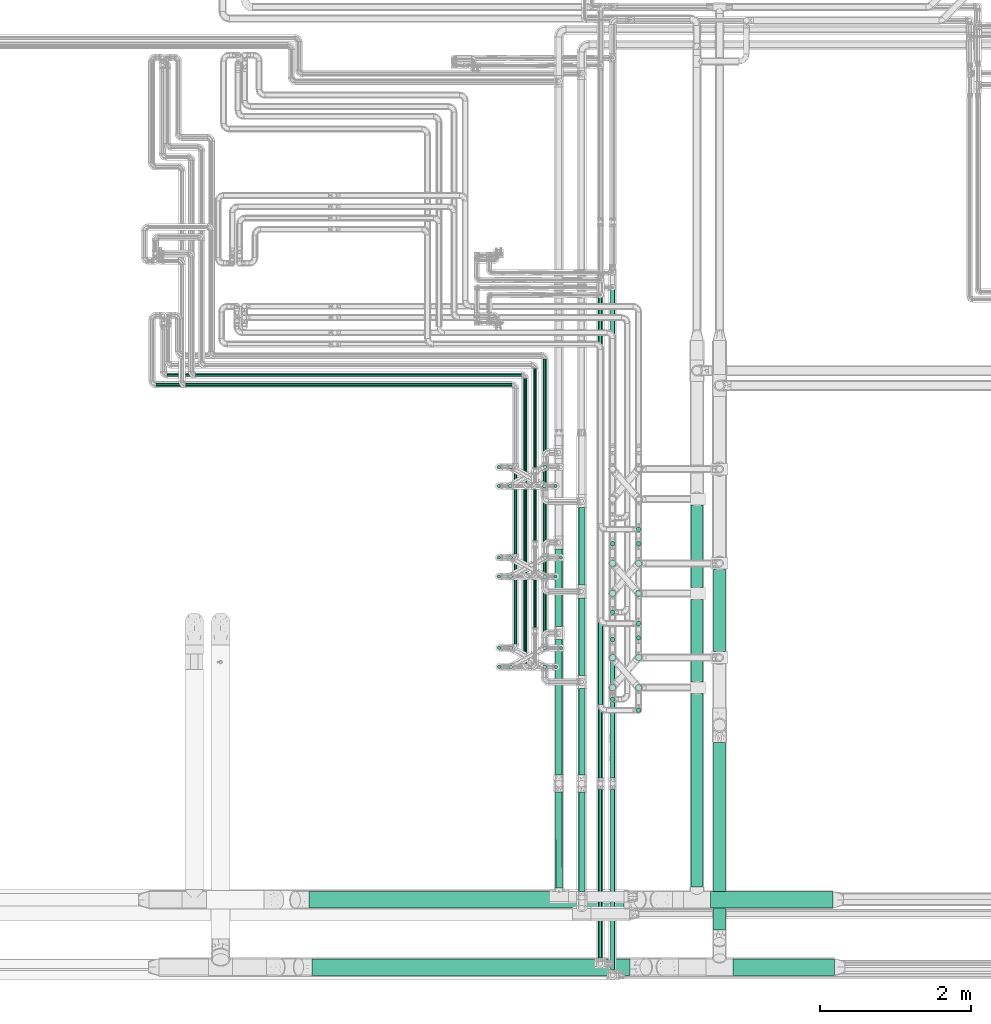
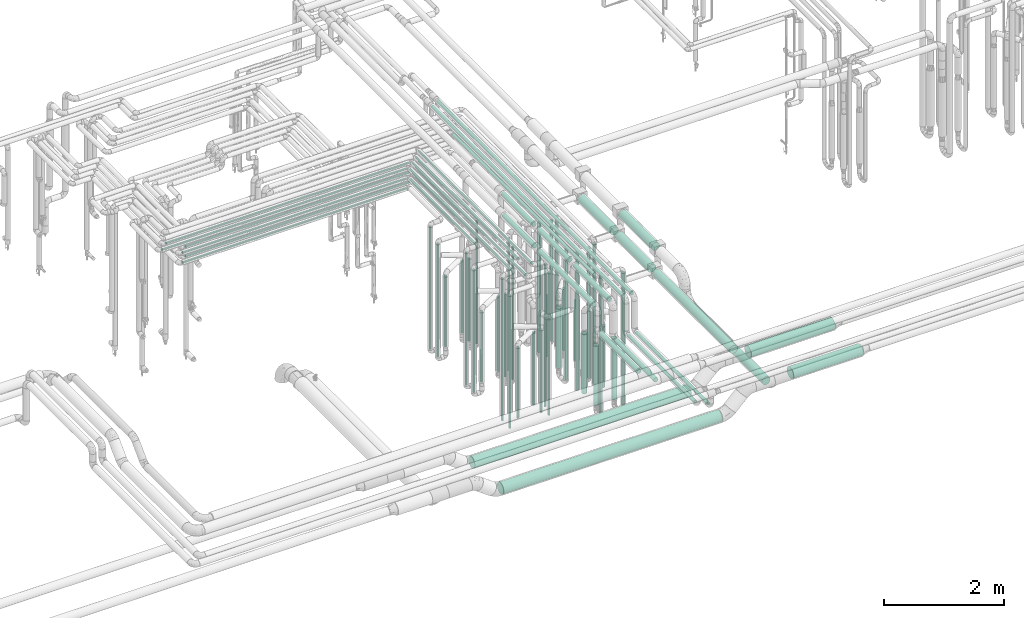
# One storey, part 530 of 827: 78 flow segments.
"""IFC2X3 building model written with IfcOpenShell, lengths in millimetres."""

from ifc_helpers import new_model, entity, si_unit, converted_unit, derived_unit, direction, frame, origin, origin_2d_with_axis, place, context, subcontext, project, spatial, polyline, circle, outline, extrude, type_object, element, save


model = new_model("IFC2X3")

# Units and contexts
model_context = context("Model", 3, precision=0.01, world=origin(), true_north=direction((6.12303176911189e-17, 1.0)))
body_context = subcontext(model_context, "Body", "Model", "MODEL_VIEW")
ifc_project = project(units=[si_unit("LENGTHUNIT", "METRE", prefix="MILLI"), si_unit("AREAUNIT", "SQUARE_METRE"), si_unit("VOLUMEUNIT", "CUBIC_METRE"), converted_unit("PLANEANGLEUNIT", "DEGREE", entity("IfcRatioMeasure", 0.0174532925199433), si_unit("PLANEANGLEUNIT", "RADIAN"), dimensions=[0, 0, 0, 0, 0, 0, 0]), si_unit("MASSUNIT", "GRAM", prefix="KILO"), derived_unit("MASSDENSITYUNIT", [(si_unit("MASSUNIT", "GRAM", prefix="KILO"), 1), (si_unit("LENGTHUNIT", "METRE"), -3)]), derived_unit("MOMENTOFINERTIAUNIT", [(si_unit("LENGTHUNIT", "METRE"), 4)]), si_unit("TIMEUNIT", "SECOND"), si_unit("FREQUENCYUNIT", "HERTZ"), si_unit("THERMODYNAMICTEMPERATUREUNIT", "DEGREE_CELSIUS"), derived_unit("THERMALTRANSMITTANCEUNIT", [(si_unit("MASSUNIT", "GRAM", prefix="KILO"), 1), (si_unit("THERMODYNAMICTEMPERATUREUNIT", "KELVIN"), -1), (si_unit("TIMEUNIT", "SECOND"), -3)]), derived_unit("VOLUMETRICFLOWRATEUNIT", [(si_unit("LENGTHUNIT", "METRE"), 3), (si_unit("TIMEUNIT", "SECOND"), -1)]), derived_unit("MASSFLOWRATEUNIT", [(si_unit("MASSUNIT", "GRAM", prefix="KILO"), 1), (si_unit("TIMEUNIT", "SECOND"), -1)]), derived_unit("ROTATIONALFREQUENCYUNIT", [(si_unit("TIMEUNIT", "SECOND"), -1)]), si_unit("ELECTRICCURRENTUNIT", "AMPERE"), si_unit("ELECTRICVOLTAGEUNIT", "VOLT"), si_unit("POWERUNIT", "WATT"), si_unit("FORCEUNIT", "NEWTON", prefix="KILO"), si_unit("ILLUMINANCEUNIT", "LUX"), si_unit("LUMINOUSFLUXUNIT", "LUMEN"), si_unit("LUMINOUSINTENSITYUNIT", "CANDELA"), derived_unit("USERDEFINED", [(si_unit("MASSUNIT", "GRAM", prefix="KILO"), -1), (si_unit("LENGTHUNIT", "METRE"), -2), (si_unit("TIMEUNIT", "SECOND"), 3), (si_unit("LUMINOUSFLUXUNIT", "LUMEN"), 1)]), derived_unit("LINEARVELOCITYUNIT", [(si_unit("LENGTHUNIT", "METRE"), 1), (si_unit("TIMEUNIT", "SECOND"), -1)]), si_unit("PRESSUREUNIT", "PASCAL"), derived_unit("USERDEFINED", [(si_unit("LENGTHUNIT", "METRE"), -2), (si_unit("MASSUNIT", "GRAM", prefix="KILO"), 1), (si_unit("TIMEUNIT", "SECOND"), -2)]), derived_unit("LINEARFORCEUNIT", [(si_unit("MASSUNIT", "GRAM", prefix="KILO"), 1), (si_unit("LENGTHUNIT", "METRE"), 1), (si_unit("TIMEUNIT", "SECOND"), -2), (si_unit("LENGTHUNIT", "METRE"), -1)]), derived_unit("PLANARFORCEUNIT", [(si_unit("MASSUNIT", "GRAM", prefix="KILO"), 1), (si_unit("LENGTHUNIT", "METRE"), 1), (si_unit("TIMEUNIT", "SECOND"), -2), (si_unit("LENGTHUNIT", "METRE"), -2)])], contexts=[model_context])

# Site, building, storey
site_placement = place(None, origin())
site = spatial("IfcSite", under=ifc_project, at=site_placement, CompositionType="ELEMENT")
building_placement = place(site_placement, origin())
building = spatial("IfcBuilding", under=site, at=building_placement, CompositionType="ELEMENT")
storey_placement = place(building_placement, frame((0.0, 0.0, 28200.0)))
storey = spatial("IfcBuildingStorey", under=building, at=storey_placement, Name="08", CompositionType="ELEMENT", Elevation=28200.0)

# Flow segments
pipe_segment_type_1 = type_object("IfcPipeSegmentType", PredefinedType="NOTDEFINED")
flow_segment_1_placement = place(storey_placement, frame((37926.3, 7155.11, 2788.77)))
element("IfcFlowSegment", 1, at=flow_segment_1_placement, inside=storey, type_object=pipe_segment_type_1, context=body_context, shape_type="SweptSolid", body=[
    extrude(circle(Radius=109.5, at=origin_2d_with_axis()), frame((0.0, 111.1, 111.1), z_axis=(1.0, 0.0, 4.27481930386784e-06), x_axis=(0.0, -1.0, 0.0)), (0.0, 0.0, 1.0), 1624.74567570153),
])
flow_segment_2_placement = place(storey_placement, frame((38226.3, 6263.9, 2788.9)))
element("IfcFlowSegment", 2, at=flow_segment_2_placement, inside=storey, type_object=pipe_segment_type_1, context=body_context, shape_type="SweptSolid", body=[
    extrude(circle(Radius=109.5, at=origin_2d_with_axis()), frame((0.0, 111.1, 111.1), z_axis=(1.0, 0.0, 0.0), x_axis=(0.0, -1.0, 0.0)), (0.0, 0.0, 1.0), 1348.80954210605),
])
flow_segment_3_placement = place(storey_placement, frame((37967.2, 6868.2, 2418.9)))
element("IfcFlowSegment", 3, at=flow_segment_3_placement, inside=storey, type_object=pipe_segment_type_1, context=body_context, shape_type="SweptSolid", body=[
    extrude(circle(Radius=79.5, at=origin_2d_with_axis()), frame((81.1, 0.0, 81.1), z_axis=(0.0, 1.0, 0.0), x_axis=(1.0, 0.0, 0.0)), (0.0, 0.0, 1.0), 2485.51890325304),
])
flow_segment_4_placement = place(storey_placement, frame((37967.2, 10557.7, 2918.9)))
element("IfcFlowSegment", 4, at=flow_segment_4_placement, inside=storey, type_object=pipe_segment_type_1, context=body_context, shape_type="SweptSolid", body=[
    extrude(circle(Radius=79.5, at=origin_2d_with_axis()), frame((81.1, 0.0, 81.1), z_axis=(0.0, 1.0, 0.0), x_axis=(-1.0, 0.0, 0.0)), (0.0, 0.0, 1.0), 1095.00000000002),
])
flow_segment_5_placement = place(storey_placement, frame((32643.13, 6263.9, 2388.9)))
element("IfcFlowSegment", 5, at=flow_segment_5_placement, inside=storey, type_object=pipe_segment_type_1, context=body_context, shape_type="SweptSolid", body=[
    extrude(circle(Radius=109.5, at=origin_2d_with_axis()), frame((0.0, 111.1, 111.1), z_axis=(1.0, 0.0, 0.0), x_axis=(0.0, -1.0, 0.0)), (0.0, 0.0, 1.0), 4214.83070096532),
])
flow_segment_6_placement = place(storey_placement, frame((32603.88, 7155.11, 2388.87)))
element("IfcFlowSegment", 6, at=flow_segment_6_placement, inside=storey, type_object=pipe_segment_type_1, context=body_context, shape_type="SweptSolid", body=[
    extrude(circle(Radius=109.5, at=origin_2d_with_axis()), frame((0.0, 111.1, 111.1), z_axis=(1.0, 0.0, 0.0), x_axis=(0.0, 1.0, 0.0)), (0.0, 0.0, 1.0), 4174.30145695319),
])
flow_segment_7_placement = place(storey_placement, frame((37667.2, 11407.7, 2818.81)))
element("IfcFlowSegment", 7, at=flow_segment_7_placement, inside=storey, type_object=pipe_segment_type_1, context=body_context, shape_type="SweptSolid", body=[
    extrude(circle(Radius=79.5, at=origin_2d_with_axis()), frame((81.1, 0.0, 81.1), z_axis=(0.0, 1.0, 0.0), x_axis=(1.0, 0.0, 0.0)), (0.0, 0.0, 1.0), 1095.97124281474),
])
flow_segment_8_placement = place(storey_placement, frame((37667.2, 10157.7, 2818.81)))
element("IfcFlowSegment", 8, at=flow_segment_8_placement, inside=storey, type_object=pipe_segment_type_1, context=body_context, shape_type="SweptSolid", body=[
    extrude(circle(Radius=79.5, at=origin_2d_with_axis()), frame((81.1, 0.0, 81.1), z_axis=(0.0, 1.0, 0.0), x_axis=(1.0, 0.0, 0.0)), (0.0, 0.0, 1.0), 1095.00000000005),
])
flow_segment_9_placement = place(storey_placement, frame((37667.2, 7434.2, 2818.81)))
element("IfcFlowSegment", 9, at=flow_segment_9_placement, inside=storey, type_object=pipe_segment_type_1, context=body_context, shape_type="SweptSolid", body=[
    extrude(circle(Radius=79.5, at=origin_2d_with_axis()), frame((81.1, 0.0, 81.1), z_axis=(0.0, 1.0, 0.0), x_axis=(1.0, 0.0, 0.0)), (0.0, 0.0, 1.0), 2568.50011294166),
])
pipe_segment_type_2 = type_object("IfcPipeSegmentType", PredefinedType="NOTDEFINED")
flow_segment_10_placement = place(storey_placement, frame((36943.44, 12149.58, 476.0)))
element("IfcFlowSegment", 10, at=flow_segment_10_placement, inside=storey, type_object=pipe_segment_type_2, context=body_context, shape_type="SweptSolid", body=[
    extrude(outline(polyline([(-3.92, -29.74), (3.92, -29.74), (11.48, -27.72), (18.26, -23.8), (23.8, -18.26), (27.72, -11.48), (29.74, -3.92), (29.74, 3.92), (27.72, 11.48), (23.8, 18.26), (18.26, 23.8), (11.48, 27.72), (3.92, 29.74), (-3.92, 29.74), (-11.48, 27.72), (-18.26, 23.8), (-23.8, 18.26), (-27.72, 11.48), (-29.74, 3.92), (-29.74, -3.92), (-27.72, -11.48), (-23.8, -18.26), (-18.26, -23.8), (-11.48, -27.72), (-3.92, -29.74)])), frame((31.6, 31.6, 0.0), z_axis=(-3.67815026440057e-09, 0.0, 1.0), x_axis=(-0.130526192220067, 0.991444861373808, 0.0)), (0.0, 0.0, 1.0), 2447.99999099997),
])
for number, where in (
    (11, (31094.52, 14207.26, 2977.25)),
    (12, (30964.52, 14077.26, 2977.25)),
):
    element("IfcFlowSegment", number, at=place(storey_placement, frame(where)), inside=storey, type_object=pipe_segment_type_2, context=body_context, shape_type="SweptSolid", body=[
        extrude(circle(Radius=21.15, at=origin_2d_with_axis()), frame((0.0, 22.75, 22.75), z_axis=(1.0, 0.0, 0.0), x_axis=(0.0, -1.0, 0.0)), (0.0, 0.0, 1.0), 4327.51165000003),
    ])
flow_segment_11_placement = place(storey_placement, frame((35707.29, 13054.2, 2977.25)))
element("IfcFlowSegment", 13, at=flow_segment_11_placement, inside=storey, type_object=pipe_segment_type_2, context=body_context, shape_type="SweptSolid", body=[
    extrude(circle(Radius=21.15, at=origin_2d_with_axis()), frame((22.75, 0.0, 22.75), z_axis=(0.0, 1.0, 0.0), x_axis=(-1.0, 0.0, 0.0)), (0.0, 0.0, 1.0), 1387.79707398041),
])
flow_segment_12_placement = place(storey_placement, frame((35577.35, 13004.17, 2977.25)))
element("IfcFlowSegment", 14, at=flow_segment_12_placement, inside=storey, type_object=pipe_segment_type_2, context=body_context, shape_type="SweptSolid", body=[
    extrude(circle(Radius=21.15, at=origin_2d_with_axis()), frame((22.75, 0.0, 22.75), z_axis=(0.0, 1.0, 0.0), x_axis=(-1.0, 0.0, 0.0)), (0.0, 0.0, 1.0), 1307.82580405416),
])
flow_segment_13_placement = place(storey_placement, frame((35447.29, 12804.17, 2977.25)))
element("IfcFlowSegment", 15, at=flow_segment_13_placement, inside=storey, type_object=pipe_segment_type_2, context=body_context, shape_type="SweptSolid", body=[
    extrude(circle(Radius=21.15, at=origin_2d_with_axis()), frame((22.75, 0.0, 22.75), z_axis=(0.0, 1.0, 0.0), x_axis=(-1.0, 0.0, 0.0)), (0.0, 0.0, 1.0), 1377.83166077068),
])
flow_segment_14_placement = place(storey_placement, frame((35097.29, 12983.46, 448.0)))
element("IfcFlowSegment", 16, at=flow_segment_14_placement, inside=storey, type_object=pipe_segment_type_2, context=body_context, shape_type="SweptSolid", body=[
    extrude(circle(Radius=21.15, at=origin_2d_with_axis()), frame((22.75, 22.75, 0.0)), (0.0, 0.0, 1.0), 2504.0),
])
flow_segment_15_placement = place(storey_placement, frame((35097.29, 12733.46, 448.0)))
element("IfcFlowSegment", 17, at=flow_segment_15_placement, inside=storey, type_object=pipe_segment_type_2, context=body_context, shape_type="SweptSolid", body=[
    extrude(circle(Radius=21.15, at=origin_2d_with_axis()), frame((22.75, 22.75, 0.0)), (0.0, 0.0, 1.0), 2303.60885615262),
])
flow_segment_16_placement = place(storey_placement, frame((35851.04, 12733.42, 448.0)))
element("IfcFlowSegment", 18, at=flow_segment_16_placement, inside=storey, type_object=pipe_segment_type_2, context=body_context, shape_type="SweptSolid", body=[
    extrude(circle(Radius=21.15, at=origin_2d_with_axis()), frame((22.75, 22.75, 0.0)), (0.0, 0.0, 1.0), 2504.0),
])
flow_segment_17_placement = place(storey_placement, frame((36438.44, 9857.02, 3368.4)))
element("IfcFlowSegment", 19, at=flow_segment_17_placement, inside=storey, type_object=pipe_segment_type_2, context=body_context, shape_type="SweptSolid", body=[
    extrude(circle(Radius=30.0, at=origin_2d_with_axis()), frame((31.6, 0.0, 31.6), z_axis=(0.0, 1.0, 0.0), x_axis=(1.0, 0.0, 0.0)), (0.0, 0.0, 1.0), 4706.97582205429),
])
flow_segment_18_placement = place(storey_placement, frame((36943.44, 10899.58, 476.0)))
element("IfcFlowSegment", 20, at=flow_segment_18_placement, inside=storey, type_object=pipe_segment_type_2, context=body_context, shape_type="SweptSolid", body=[
    extrude(circle(Radius=30.0, at=origin_2d_with_axis()), frame((31.6, 31.6, 0.0), z_axis=(0.0, 0.0, 1.0), x_axis=(-1.0, 0.0, 0.0)), (3.39879591138015e-09, 0.0, 1.0), 2647.99999099998),
])
flow_segment_19_placement = place(storey_placement, frame((36598.05, 11958.61, 476.0)))
element("IfcFlowSegment", 21, at=flow_segment_19_placement, inside=storey, type_object=pipe_segment_type_2, context=body_context, shape_type="SweptSolid", body=[
    extrude(circle(Radius=30.0, at=origin_2d_with_axis()), frame((31.6, 31.6, 0.0)), (0.0, 0.0, 1.0), 2648.0),
])
flow_segment_20_placement = place(storey_placement, frame((36583.8, 11684.36, 565.0)))
element("IfcFlowSegment", 22, at=flow_segment_20_placement, inside=storey, type_object=pipe_segment_type_2, context=body_context, shape_type="SweptSolid", body=[
    extrude(circle(Radius=44.25, at=origin_2d_with_axis()), frame((45.85, 45.85, 0.0)), (0.0, 0.0, 1.0), 1215.99999999999),
])
flow_segment_21_placement = place(storey_placement, frame((36943.44, 11958.61, 476.0)))
element("IfcFlowSegment", 23, at=flow_segment_21_placement, inside=storey, type_object=pipe_segment_type_2, context=body_context, shape_type="SweptSolid", body=[
    extrude(circle(Radius=30.0, at=origin_2d_with_axis()), frame((31.6, 31.6, 0.0)), (0.0, 0.0, 1.0), 2648.0),
])
flow_segment_22_placement = place(storey_placement, frame((36583.8, 11285.75, 565.0)))
element("IfcFlowSegment", 24, at=flow_segment_22_placement, inside=storey, type_object=pipe_segment_type_2, context=body_context, shape_type="SweptSolid", body=[
    extrude(circle(Radius=44.25, at=origin_2d_with_axis()), frame((45.85, 45.85, 0.0), z_axis=(0.0, 0.0, 1.0), x_axis=(-1.0, 0.0, 0.0)), (0.0, 0.0, 1.0), 1215.99999099996),
])
flow_segment_23_placement = place(storey_placement, frame((36598.05, 11049.58, 476.0)))
element("IfcFlowSegment", 25, at=flow_segment_23_placement, inside=storey, type_object=pipe_segment_type_2, context=body_context, shape_type="SweptSolid", body=[
    extrude(circle(Radius=30.0, at=origin_2d_with_axis()), frame((31.6, 31.6, 0.0), z_axis=(0.0, 0.0, 1.0), x_axis=(-1.0, 0.0, 0.0)), (0.0, 0.0, 1.0), 2647.99999099998),
])
flow_segment_24_placement = place(storey_placement, frame((36943.44, 9749.43, 476.0)))
element("IfcFlowSegment", 26, at=flow_segment_24_placement, inside=storey, type_object=pipe_segment_type_2, context=body_context, shape_type="SweptSolid", body=[
    extrude(circle(Radius=30.0, at=origin_2d_with_axis()), frame((31.6, 31.6, 0.0), z_axis=(0.0, 0.0, 1.0), x_axis=(-1.0, 0.0, 0.0)), (3.16011039558362e-09, 0.0, 1.0), 2847.99999099998),
])
flow_segment_25_placement = place(storey_placement, frame((36598.05, 10688.13, 476.0)))
element("IfcFlowSegment", 27, at=flow_segment_25_placement, inside=storey, type_object=pipe_segment_type_2, context=body_context, shape_type="SweptSolid", body=[
    extrude(circle(Radius=30.0, at=origin_2d_with_axis()), frame((31.6, 31.6, 0.0)), (0.0, 0.0, 1.0), 2847.99999999999),
])
flow_segment_26_placement = place(storey_placement, frame((36583.8, 10434.36, 565.0)))
element("IfcFlowSegment", 28, at=flow_segment_26_placement, inside=storey, type_object=pipe_segment_type_2, context=body_context, shape_type="SweptSolid", body=[
    extrude(circle(Radius=44.25, at=origin_2d_with_axis()), frame((45.85, 45.85, 0.0)), (0.0, 0.0, 1.0), 1215.99999999998),
])
flow_segment_27_placement = place(storey_placement, frame((36943.44, 10708.61, 476.0)))
element("IfcFlowSegment", 29, at=flow_segment_27_placement, inside=storey, type_object=pipe_segment_type_2, context=body_context, shape_type="SweptSolid", body=[
    extrude(circle(Radius=30.0, at=origin_2d_with_axis()), frame((31.6, 31.6, 0.0)), (0.0, 0.0, 1.0), 2848.0),
])
flow_segment_28_placement = place(storey_placement, frame((36929.19, 10434.36, 565.0)))
element("IfcFlowSegment", 30, at=flow_segment_28_placement, inside=storey, type_object=pipe_segment_type_2, context=body_context, shape_type="SweptSolid", body=[
    extrude(circle(Radius=44.25, at=origin_2d_with_axis()), frame((45.85, 45.85, 0.0)), (0.0, 0.0, 1.0), 1245.99999999999),
])
flow_segment_29_placement = place(storey_placement, frame((36583.8, 10035.75, 565.0)))
element("IfcFlowSegment", 31, at=flow_segment_29_placement, inside=storey, type_object=pipe_segment_type_2, context=body_context, shape_type="SweptSolid", body=[
    extrude(circle(Radius=44.25, at=origin_2d_with_axis()), frame((45.85, 45.85, 0.0), z_axis=(0.0, 0.0, 1.0), x_axis=(-1.0, 0.0, 0.0)), (0.0, 0.0, 1.0), 1215.99999099995),
])
flow_segment_30_placement = place(storey_placement, frame((36598.05, 9894.58, 476.0)))
element("IfcFlowSegment", 32, at=flow_segment_30_placement, inside=storey, type_object=pipe_segment_type_2, context=body_context, shape_type="SweptSolid", body=[
    extrude(circle(Radius=30.0, at=origin_2d_with_axis()), frame((31.6, 31.6, 0.0), z_axis=(0.0, 0.0, 1.0), x_axis=(-1.0, 0.0, 0.0)), (0.0, 0.0, 1.0), 2847.99999099997),
])
flow_segment_31_placement = place(storey_placement, frame((36929.19, 11684.36, 565.0)))
element("IfcFlowSegment", 33, at=flow_segment_31_placement, inside=storey, type_object=pipe_segment_type_2, context=body_context, shape_type="SweptSolid", body=[
    extrude(circle(Radius=44.25, at=origin_2d_with_axis()), frame((45.85, 45.85, 0.0), z_axis=(0.0, 0.0, 1.0), x_axis=(-1.0, 0.0, 0.0)), (0.0, 0.0, 1.0), 1246.0),
])
flow_segment_32_placement = place(storey_placement, frame((31094.52, 14207.26, 3177.25)))
element("IfcFlowSegment", 34, at=flow_segment_32_placement, inside=storey, type_object=pipe_segment_type_2, context=body_context, shape_type="SweptSolid", body=[
    extrude(circle(Radius=21.15, at=origin_2d_with_axis()), frame((0.0, 22.75, 22.75), z_axis=(1.0, 0.0, 0.0), x_axis=(0.0, 1.0, 0.0)), (0.0, 0.0, 1.0), 4327.51165000006),
])
flow_segment_33_placement = place(storey_placement, frame((30964.52, 14077.26, 3177.25)))
element("IfcFlowSegment", 35, at=flow_segment_33_placement, inside=storey, type_object=pipe_segment_type_2, context=body_context, shape_type="SweptSolid", body=[
    extrude(circle(Radius=21.15, at=origin_2d_with_axis()), frame((0.0, 22.75, 22.75), z_axis=(1.0, 0.0, 0.0), x_axis=(0.0, 1.0, 0.0)), (0.0, 0.0, 1.0), 4327.51165000005),
])
flow_segment_34_placement = place(storey_placement, frame((30718.34, 14207.26, 3377.25)))
element("IfcFlowSegment", 36, at=flow_segment_34_placement, inside=storey, type_object=pipe_segment_type_2, context=body_context, shape_type="SweptSolid", body=[
    extrude(circle(Radius=21.15, at=origin_2d_with_axis()), frame((0.0, 22.75, 22.75), z_axis=(1.0, 0.0, 0.0), x_axis=(0.0, 1.0, 0.0)), (0.0, 0.0, 1.0), 4703.69587000002),
])
flow_segment_35_placement = place(storey_placement, frame((30569.52, 14077.26, 3377.25)))
element("IfcFlowSegment", 37, at=flow_segment_35_placement, inside=storey, type_object=pipe_segment_type_2, context=body_context, shape_type="SweptSolid", body=[
    extrude(circle(Radius=21.15, at=origin_2d_with_axis()), frame((0.0, 22.75, 22.75), z_axis=(1.0, 0.0, 0.0), x_axis=(0.0, 1.0, 0.0)), (0.0, 0.0, 1.0), 4722.51165000002),
])
flow_segment_36_placement = place(storey_placement, frame((35097.29, 11783.46, 448.0)))
element("IfcFlowSegment", 38, at=flow_segment_36_placement, inside=storey, type_object=pipe_segment_type_2, context=body_context, shape_type="SweptSolid", body=[
    extrude(circle(Radius=21.15, at=origin_2d_with_axis()), frame((22.75, 22.75, 0.0), z_axis=(0.0, 0.0, 1.0), x_axis=(-1.0, 0.0, 0.0)), (0.0, 0.0, 1.0), 2704.00000000002),
])
flow_segment_37_placement = place(storey_placement, frame((35097.29, 11533.46, 448.0)))
element("IfcFlowSegment", 39, at=flow_segment_37_placement, inside=storey, type_object=pipe_segment_type_2, context=body_context, shape_type="SweptSolid", body=[
    extrude(circle(Radius=21.15, at=origin_2d_with_axis()), frame((22.75, 22.75, 0.0), z_axis=(0.0, 0.0, 1.0), x_axis=(-1.0, 0.0, 0.0)), (0.0, 0.0, 1.0), 2504.00000000002),
])
flow_segment_38_placement = place(storey_placement, frame((35851.04, 11533.42, 448.0)))
element("IfcFlowSegment", 40, at=flow_segment_38_placement, inside=storey, type_object=pipe_segment_type_2, context=body_context, shape_type="SweptSolid", body=[
    extrude(circle(Radius=21.15, at=origin_2d_with_axis()), frame((22.75, 22.75, 0.0)), (0.0, 0.0, 1.0), 2704.00000000003),
])
flow_segment_39_placement = place(storey_placement, frame((35920.3, 11783.46, 448.0)))
element("IfcFlowSegment", 41, at=flow_segment_39_placement, inside=storey, type_object=pipe_segment_type_2, context=body_context, shape_type="SweptSolid", body=[
    extrude(circle(Radius=21.15, at=origin_2d_with_axis()), frame((22.75, 22.75, 0.0), z_axis=(0.0, 0.0, 1.0), x_axis=(-1.0, 0.0, 0.0)), (0.0, 0.0, 1.0), 2704.00000000003),
])
flow_segment_40_placement = place(storey_placement, frame((35102.29, 10586.4, 448.0)))
element("IfcFlowSegment", 42, at=flow_segment_40_placement, inside=storey, type_object=pipe_segment_type_2, context=body_context, shape_type="SweptSolid", body=[
    extrude(circle(Radius=21.15, at=origin_2d_with_axis()), frame((22.75, 22.75, 0.0), z_axis=(0.0, 0.0, 1.0), x_axis=(-1.0, 0.0, 0.0)), (0.0, 0.0, 1.0), 2904.0),
])
flow_segment_41_placement = place(storey_placement, frame((35102.29, 10334.34, 448.0)))
element("IfcFlowSegment", 43, at=flow_segment_41_placement, inside=storey, type_object=pipe_segment_type_2, context=body_context, shape_type="SweptSolid", body=[
    extrude(circle(Radius=21.15, at=origin_2d_with_axis()), frame((22.75, 22.75, 0.0), z_axis=(0.0, 0.0, 1.0), x_axis=(-1.0, 0.0, 0.0)), (0.0, 0.0, 1.0), 2704.00000000001),
])
flow_segment_42_placement = place(storey_placement, frame((35856.04, 10333.42, 448.0)))
element("IfcFlowSegment", 44, at=flow_segment_42_placement, inside=storey, type_object=pipe_segment_type_2, context=body_context, shape_type="SweptSolid", body=[
    extrude(circle(Radius=21.15, at=origin_2d_with_axis()), frame((22.75, 22.75, 0.0), z_axis=(0.0, 0.0, 1.0), x_axis=(-1.0, 0.0, 0.0)), (0.0, 0.0, 1.0), 2904.00000000001),
])
flow_segment_43_placement = place(storey_placement, frame((35925.3, 10583.46, 448.0)))
element("IfcFlowSegment", 45, at=flow_segment_43_placement, inside=storey, type_object=pipe_segment_type_2, context=body_context, shape_type="SweptSolid", body=[
    extrude(circle(Radius=21.15, at=origin_2d_with_axis()), frame((22.75, 22.75, 0.0)), (0.0, 0.0, 1.0), 2904.00000000001),
])
flow_segment_44_placement = place(storey_placement, frame((36174.19, 8921.39, 3504.16)))
element("IfcFlowSegment", 46, at=flow_segment_44_placement, inside=storey, type_object=pipe_segment_type_2, context=body_context, shape_type="SweptSolid", body=[
    extrude(circle(Radius=44.25, at=origin_2d_with_axis()), frame((45.85, 0.0, 45.85), z_axis=(0.0, 1.0, 0.0), x_axis=(-1.0, 0.0, 0.0)), (0.0, 0.0, 1.0), 1148.81413940413),
])
flow_segment_45_placement = place(storey_placement, frame((36174.19, 7376.95, 2804.15)))
element("IfcFlowSegment", 47, at=flow_segment_45_placement, inside=storey, type_object=pipe_segment_type_2, context=body_context, shape_type="SweptSolid", body=[
    extrude(circle(Radius=44.25, at=origin_2d_with_axis()), frame((45.85, 0.0, 45.85), z_axis=(0.0, 1.0, 0.0), x_axis=(-1.0, 0.0, 0.0)), (0.0, 0.0, 1.0), 1316.44024231723),
])
flow_segment_46_placement = place(storey_placement, frame((35872.22, 8921.39, 3504.16)))
element("IfcFlowSegment", 48, at=flow_segment_46_placement, inside=storey, type_object=pipe_segment_type_2, context=body_context, shape_type="SweptSolid", body=[
    extrude(circle(Radius=44.25, at=origin_2d_with_axis()), frame((45.85, 0.0, 45.85), z_axis=(0.0, 1.0, 0.0), x_axis=(-1.0, 0.0, 0.0)), (0.0, 0.0, 1.0), 1798.81487069226),
])
flow_segment_47_placement = place(storey_placement, frame((35872.2, 7422.7, 3054.15)))
element("IfcFlowSegment", 49, at=flow_segment_47_placement, inside=storey, type_object=pipe_segment_type_2, context=body_context, shape_type="SweptSolid", body=[
    extrude(circle(Radius=44.25, at=origin_2d_with_axis()), frame((45.85, 1270.69, 45.85), z_axis=(0.000807635041357438, -0.999999673862767, 0.0), x_axis=(-0.999999673862767, -0.000807635041357438, 0.0)), (0.0, 0.0, 1.0), 1270.65564093795),
])
flow_segment_48_placement = place(storey_placement, frame((35707.29, 11854.2, 3177.25)))
element("IfcFlowSegment", 50, at=flow_segment_48_placement, inside=storey, type_object=pipe_segment_type_2, context=body_context, shape_type="SweptSolid", body=[
    extrude(circle(Radius=21.15, at=origin_2d_with_axis()), frame((22.75, 0.0, 22.75), z_axis=(0.0, 1.0, 0.0), x_axis=(1.0, 0.0, 0.0)), (0.0, 0.0, 1.0), 2587.79707398043),
])
flow_segment_49_placement = place(storey_placement, frame((35577.35, 12031.2, 3177.25)))
element("IfcFlowSegment", 51, at=flow_segment_49_placement, inside=storey, type_object=pipe_segment_type_2, context=body_context, shape_type="SweptSolid", body=[
    extrude(circle(Radius=21.15, at=origin_2d_with_axis()), frame((22.75, 0.0, 22.75), z_axis=(0.0, 1.0, 0.0), x_axis=(-1.0, 0.0, 0.0)), (0.0, 0.0, 1.0), 2280.79727405418),
])
flow_segment_50_placement = place(storey_placement, frame((35317.29, 11854.2, 3177.25)))
element("IfcFlowSegment", 52, at=flow_segment_50_placement, inside=storey, type_object=pipe_segment_type_2, context=body_context, shape_type="SweptSolid", body=[
    extrude(circle(Radius=21.15, at=origin_2d_with_axis()), frame((22.75, 0.0, 22.75), z_axis=(0.0, 1.0, 0.0), x_axis=(1.0, 0.0, 0.0)), (0.0, 0.0, 1.0), 2197.79707405417),
])
flow_segment_51_placement = place(storey_placement, frame((35447.29, 11604.17, 3177.25)))
element("IfcFlowSegment", 53, at=flow_segment_51_placement, inside=storey, type_object=pipe_segment_type_2, context=body_context, shape_type="SweptSolid", body=[
    extrude(circle(Radius=21.15, at=origin_2d_with_axis()), frame((22.75, 0.0, 22.75), z_axis=(0.0, 1.0, 0.0), x_axis=(1.0, 0.0, 0.0)), (0.0, 0.0, 1.0), 2577.83166077068),
])
flow_segment_52_placement = place(storey_placement, frame((35707.29, 10654.2, 3377.25)))
element("IfcFlowSegment", 54, at=flow_segment_52_placement, inside=storey, type_object=pipe_segment_type_2, context=body_context, shape_type="SweptSolid", body=[
    extrude(circle(Radius=21.15, at=origin_2d_with_axis()), frame((22.75, 0.0, 22.75), z_axis=(0.0, 1.0, 0.0), x_axis=(-1.0, 0.0, 0.0)), (0.0, 0.0, 1.0), 3787.79707398042),
])
flow_segment_53_placement = place(storey_placement, frame((35577.35, 10876.38, 3377.25)))
element("IfcFlowSegment", 55, at=flow_segment_53_placement, inside=storey, type_object=pipe_segment_type_2, context=body_context, shape_type="SweptSolid", body=[
    extrude(circle(Radius=21.15, at=origin_2d_with_axis()), frame((22.75, 0.0, 22.75), z_axis=(0.0, 1.0, 0.0), x_axis=(-1.0, 0.0, 0.0)), (0.0, 0.0, 1.0), 3435.62396825438),
])
flow_segment_54_placement = place(storey_placement, frame((35317.29, 10657.14, 3377.25)))
element("IfcFlowSegment", 56, at=flow_segment_54_placement, inside=storey, type_object=pipe_segment_type_2, context=body_context, shape_type="SweptSolid", body=[
    extrude(circle(Radius=21.15, at=origin_2d_with_axis()), frame((22.75, 0.0, 22.75), z_axis=(0.0, 1.0, 0.0), x_axis=(1.0, 0.0, 0.0)), (0.0, 0.0, 1.0), 3394.85688841738),
])
flow_segment_55_placement = place(storey_placement, frame((35447.29, 10404.17, 3377.25)))
element("IfcFlowSegment", 57, at=flow_segment_55_placement, inside=storey, type_object=pipe_segment_type_2, context=body_context, shape_type="SweptSolid", body=[
    extrude(circle(Radius=21.15, at=origin_2d_with_axis()), frame((22.75, 0.0, 22.75), z_axis=(0.0, 1.0, 0.0), x_axis=(-1.0, 0.0, 0.0)), (0.0, 0.0, 1.0), 3777.83166077068),
])
flow_segment_56_placement = place(storey_placement, frame((36174.19, 10242.2, 3504.15)))
element("IfcFlowSegment", 58, at=flow_segment_56_placement, inside=storey, type_object=pipe_segment_type_2, context=body_context, shape_type="SweptSolid", body=[
    extrude(circle(Radius=44.25, at=origin_2d_with_axis()), frame((45.85, 0.0, 45.85), z_axis=(0.0, 1.0, 0.0), x_axis=(-1.0, 0.0, 0.0)), (0.0, 0.0, 1.0), 1027.87693556044),
])
flow_segment_57_placement = place(storey_placement, frame((35872.22, 10892.2, 3504.16)))
element("IfcFlowSegment", 59, at=flow_segment_57_placement, inside=storey, type_object=pipe_segment_type_2, context=body_context, shape_type="SweptSolid", body=[
    extrude(circle(Radius=44.25, at=origin_2d_with_axis()), frame((45.85, 0.0, 45.85), z_axis=(0.0, 1.0, 0.0), x_axis=(-1.0, 0.0, 0.0)), (0.0, 0.0, 1.0), 1027.87693556045),
])
flow_segment_58_placement = place(storey_placement, frame((36174.19, 11442.08, 3504.15)))
element("IfcFlowSegment", 60, at=flow_segment_58_placement, inside=storey, type_object=pipe_segment_type_2, context=body_context, shape_type="SweptSolid", body=[
    extrude(circle(Radius=44.25, at=origin_2d_with_axis()), frame((45.85, 0.0, 45.85), z_axis=(0.0, 1.0, 0.0), x_axis=(-1.0, 0.0, 0.0)), (0.0, 0.0, 1.0), 1028.0),
])
flow_segment_59_placement = place(storey_placement, frame((36598.05, 8883.39, 3518.4)))
element("IfcFlowSegment", 61, at=flow_segment_59_placement, inside=storey, type_object=pipe_segment_type_2, context=body_context, shape_type="SweptSolid", body=[
    extrude(circle(Radius=30.0, at=origin_2d_with_axis()), frame((31.6, 0.0, 31.6), z_axis=(0.0, 1.0, 0.0), x_axis=(-1.0, 0.0, 0.0)), (0.0, 0.0, 1.0), 6478.71001435614),
])
flow_segment_60_placement = place(storey_placement, frame((36598.05, 6341.81, 2818.4)))
element("IfcFlowSegment", 62, at=flow_segment_60_placement, inside=storey, type_object=pipe_segment_type_2, context=body_context, shape_type="SweptSolid", body=[
    extrude(circle(Radius=30.0, at=origin_2d_with_axis()), frame((31.6, 0.0, 31.6), z_axis=(0.0, 1.0, 0.0), x_axis=(1.0, 0.0, 0.0)), (0.0, 0.0, 1.0), 2389.57772043242),
])
flow_segment_61_placement = place(storey_placement, frame((36437.12, 6492.57, 2818.4)))
element("IfcFlowSegment", 63, at=flow_segment_61_placement, inside=storey, type_object=pipe_segment_type_2, context=body_context, shape_type="SweptSolid", body=[
    extrude(circle(Radius=30.0, at=origin_2d_with_axis()), frame((31.6, 0.0, 31.6), z_axis=(0.0, 1.0, 0.0), x_axis=(1.0, 0.0, 0.0)), (0.0, 0.0, 1.0), 2238.82114274712),
])
flow_segment_62_placement = place(storey_placement, frame((36437.12, 8883.39, 3518.4)))
element("IfcFlowSegment", 64, at=flow_segment_62_placement, inside=storey, type_object=pipe_segment_type_2, context=body_context, shape_type="SweptSolid", body=[
    extrude(circle(Radius=30.0, at=origin_2d_with_axis()), frame((31.6, 0.0, 31.6), z_axis=(0.0, 1.0, 0.0), x_axis=(1.0, 0.0, 0.0)), (0.0, 0.0, 1.0), 6379.11000635614),
])
flow_segment_63_placement = place(storey_placement, frame((36929.19, 10034.36, 565.0)))
element("IfcFlowSegment", 65, at=flow_segment_63_placement, inside=storey, type_object=pipe_segment_type_2, context=body_context, shape_type="SweptSolid", body=[
    extrude(circle(Radius=44.25, at=origin_2d_with_axis()), frame((45.85, 45.85, 0.0)), (0.0, 0.0, 1.0), 1245.99999099997),
])
flow_segment_64_placement = place(storey_placement, frame((36929.19, 11284.36, 589.0)))
element("IfcFlowSegment", 66, at=flow_segment_64_placement, inside=storey, type_object=pipe_segment_type_2, context=body_context, shape_type="SweptSolid", body=[
    extrude(circle(Radius=44.25, at=origin_2d_with_axis()), frame((45.85, 45.85, 0.0), z_axis=(0.0, 0.0, 1.0), x_axis=(-1.0, 0.0, 0.0)), (0.0, 0.0, 1.0), 1222.00000649532),
])
flow_segment_65_placement = place(storey_placement, frame((35253.27, 10331.49, 604.0)))
element("IfcFlowSegment", 67, at=flow_segment_65_placement, inside=storey, type_object=pipe_segment_type_2, context=body_context, shape_type="SweptSolid", body=[
    extrude(circle(Radius=24.0, at=origin_2d_with_axis()), frame((25.6, 25.6, 0.0), z_axis=(0.0, 1.97430995600526e-06, 1.0), x_axis=(-1.0, 0.0, 0.0)), (0.0, 0.0, 1.0), 1439.00000000281),
])
flow_segment_66_placement = place(storey_placement, frame((35702.45, 10330.57, 559.0)))
element("IfcFlowSegment", 68, at=flow_segment_66_placement, inside=storey, type_object=pipe_segment_type_2, context=body_context, shape_type="SweptSolid", body=[
    extrude(circle(Radius=24.0, at=origin_2d_with_axis()), frame((25.6, 25.6, 0.0), z_axis=(0.0, 0.0, 1.0), x_axis=(-1.0, 0.0, 0.0)), (0.0, 0.0, 1.0), 1688.99999999998),
])
flow_segment_67_placement = place(storey_placement, frame((35702.45, 10580.61, 559.0)))
element("IfcFlowSegment", 69, at=flow_segment_67_placement, inside=storey, type_object=pipe_segment_type_2, context=body_context, shape_type="SweptSolid", body=[
    extrude(circle(Radius=24.0, at=origin_2d_with_axis()), frame((25.6, 25.6, 0.0), z_axis=(0.0, 0.0, 1.0), x_axis=(-1.0, 0.0, 0.0)), (0.0, 0.0, 1.0), 1484.0),
])
flow_segment_68_placement = place(storey_placement, frame((35251.14, 10583.53, 604.0)))
element("IfcFlowSegment", 70, at=flow_segment_68_placement, inside=storey, type_object=pipe_segment_type_2, context=body_context, shape_type="SweptSolid", body=[
    extrude(circle(Radius=24.0, at=origin_2d_with_axis()), frame((25.6, 25.61, 0.0), z_axis=(0.0, -1.10407019482887e-05, 1.0), x_axis=(-1.0, 0.0, 0.0)), (0.0, 0.0, 1.0), 1644.00000010021),
])
flow_segment_69_placement = place(storey_placement, frame((35249.44, 11530.05, 603.99)))
element("IfcFlowSegment", 71, at=flow_segment_69_placement, inside=storey, type_object=pipe_segment_type_2, context=body_context, shape_type="SweptSolid", body=[
    extrude(circle(Radius=24.0, at=origin_2d_with_axis()), frame((25.6, 26.21, 0.01), z_axis=(0.0, -0.000429537009763512, 0.999999907748974), x_axis=(-1.0, 0.0, 0.0)), (0.0, 0.0, 1.0), 1438.97359676792),
])
flow_segment_70_placement = place(storey_placement, frame((35703.19, 11528.87, 558.98)))
element("IfcFlowSegment", 72, at=flow_segment_70_placement, inside=storey, type_object=pipe_segment_type_2, context=body_context, shape_type="SweptSolid", body=[
    extrude(circle(Radius=24.0, at=origin_2d_with_axis()), frame((25.6, 27.3, 0.02), z_axis=(0.0, -0.00101019809551677, 0.999999489749774), x_axis=(1.0, 0.0, 0.0)), (0.0, 0.0, 1.0), 1689.00086181307),
])
flow_segment_71_placement = place(storey_placement, frame((35711.26, 11780.07, 511.99)))
element("IfcFlowSegment", 73, at=flow_segment_71_placement, inside=storey, type_object=pipe_segment_type_2, context=body_context, shape_type="SweptSolid", body=[
    extrude(circle(Radius=24.0, at=origin_2d_with_axis()), frame((25.6, 26.09, 0.01), z_axis=(0.0, -0.000321811119658756, 0.9999999482188), x_axis=(-1.0, 0.0, 0.0)), (0.0, 0.0, 1.0), 1531.00008703173),
])
flow_segment_72_placement = place(storey_placement, frame((35250.64, 11782.53, 604.0)))
element("IfcFlowSegment", 74, at=flow_segment_72_placement, inside=storey, type_object=pipe_segment_type_2, context=body_context, shape_type="SweptSolid", body=[
    extrude(circle(Radius=24.0, at=origin_2d_with_axis()), frame((25.6, 25.6, 0.0), z_axis=(0.0, 0.0, 1.0), x_axis=(-1.0, 0.0, 0.0)), (0.0, 0.0, 1.0), 1643.99999999999),
])
flow_segment_73_placement = place(storey_placement, frame((35708.54, 12985.08, 559.0)))
element("IfcFlowSegment", 75, at=flow_segment_73_placement, inside=storey, type_object=pipe_segment_type_2, context=body_context, shape_type="SweptSolid", body=[
    extrude(circle(Radius=24.0, at=origin_2d_with_axis()), frame((25.6, 25.6, 0.0), z_axis=(0.0, 0.0, 1.0), x_axis=(-1.0, 0.0, 0.0)), (0.0, 0.0, 1.0), 1484.0),
])
flow_segment_74_placement = place(storey_placement, frame((35249.75, 12980.94, 604.0)))
element("IfcFlowSegment", 76, at=flow_segment_74_placement, inside=storey, type_object=pipe_segment_type_2, context=body_context, shape_type="SweptSolid", body=[
    extrude(circle(Radius=24.0, at=origin_2d_with_axis()), frame((25.6, 25.6, 0.0), z_axis=(0.0, 0.0, 1.0), x_axis=(-1.0, 0.0, 0.0)), (0.0, 0.0, 1.0), 1643.99999999999),
])
flow_segment_75_placement = place(storey_placement, frame((35699.44, 12728.87, 559.0)))
element("IfcFlowSegment", 77, at=flow_segment_75_placement, inside=storey, type_object=pipe_segment_type_2, context=body_context, shape_type="SweptSolid", body=[
    extrude(circle(Radius=24.0, at=origin_2d_with_axis()), frame((25.6, 25.6, 0.0), z_axis=(0.0, 0.0, 1.0), x_axis=(-1.0, 0.0, 0.0)), (0.0, 0.0, 1.0), 1688.99999999999),
])
flow_segment_76_placement = place(storey_placement, frame((35247.31, 12729.26, 604.0)))
element("IfcFlowSegment", 78, at=flow_segment_76_placement, inside=storey, type_object=pipe_segment_type_2, context=body_context, shape_type="SweptSolid", body=[
    extrude(circle(Radius=24.0, at=origin_2d_with_axis()), frame((25.6, 25.6, 0.0), z_axis=(0.0, 0.0, 1.0), x_axis=(-1.0, 0.0, 0.0)), (0.0, 0.0, 1.0), 1439.0),
])

save(model, "model.ifc")
